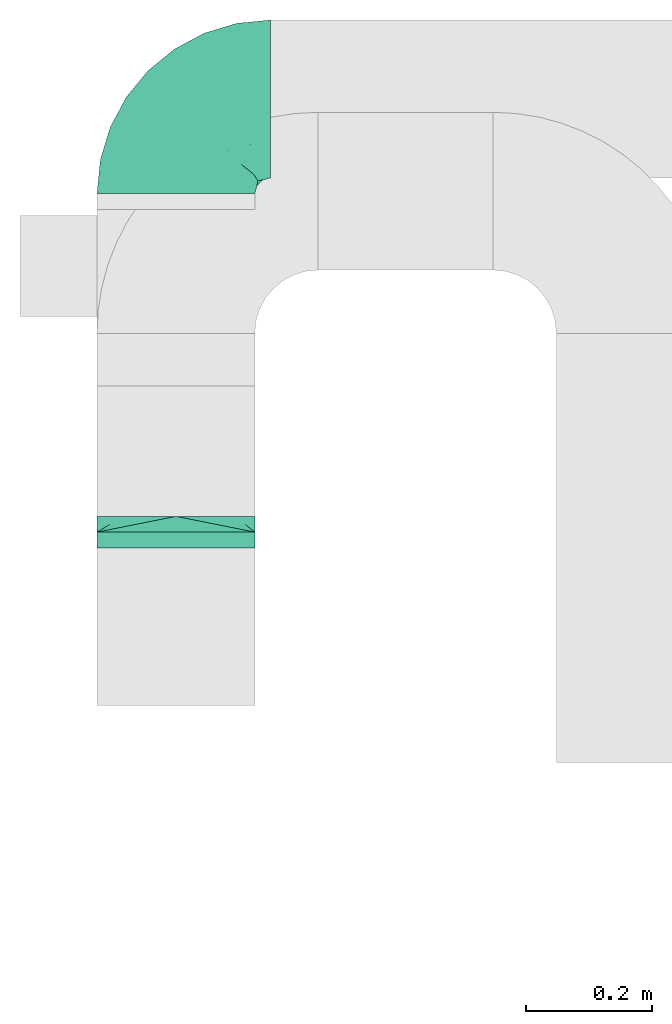
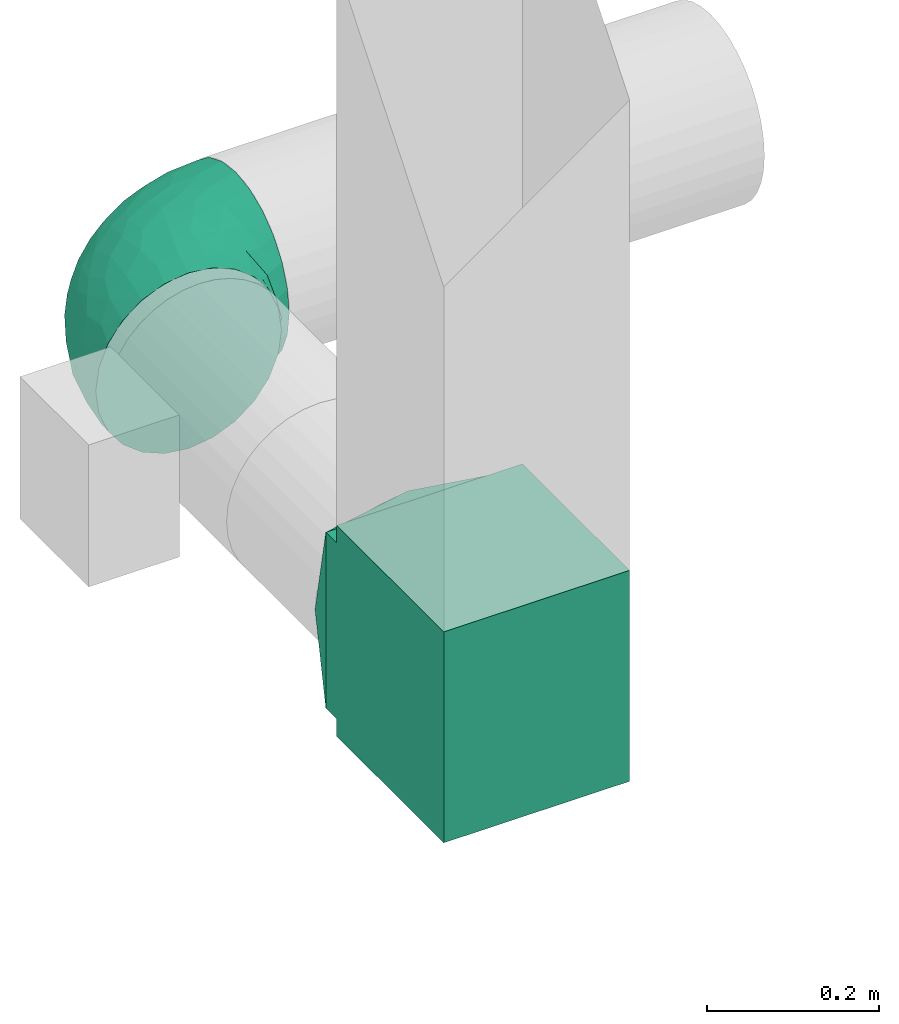
# One storey, part 3 of 5: 3 flow fittings.
"""IFC2X3 building model written with IfcOpenShell, lengths in millimetres."""

from ifc_helpers import new_model, entity, si_unit, converted_unit, derived_unit, direction, frame, origin, place, context, subcontext, project, spatial, polyline, outline, extrude, faceted_brep, source, transform, mapped, material, type_object, type_shapes, element, save


model = new_model("IFC2X3")

# Units and contexts
model_context = context("Model", 3, precision=0.01, world=origin(), true_north=direction((6.12303176911189e-17, 1.0)))
body_context = subcontext(model_context, "Body", "Model", "MODEL_VIEW")
ifc_project = project(units=[si_unit("LENGTHUNIT", "METRE", prefix="MILLI"), si_unit("AREAUNIT", "SQUARE_METRE"), si_unit("VOLUMEUNIT", "CUBIC_METRE"), converted_unit("PLANEANGLEUNIT", "DEGREE", entity("IfcRatioMeasure", 0.0174532925199433), si_unit("PLANEANGLEUNIT", "RADIAN"), dimensions=[0, 0, 0, 0, 0, 0, 0]), si_unit("MASSUNIT", "GRAM", prefix="KILO"), derived_unit("MASSDENSITYUNIT", [(si_unit("MASSUNIT", "GRAM", prefix="KILO"), 1), (si_unit("LENGTHUNIT", "METRE"), -3)]), si_unit("TIMEUNIT", "SECOND"), si_unit("FREQUENCYUNIT", "HERTZ"), si_unit("THERMODYNAMICTEMPERATUREUNIT", "DEGREE_CELSIUS"), derived_unit("THERMALTRANSMITTANCEUNIT", [(si_unit("MASSUNIT", "GRAM", prefix="KILO"), 1), (si_unit("THERMODYNAMICTEMPERATUREUNIT", "KELVIN"), -1), (si_unit("TIMEUNIT", "SECOND"), -3)]), derived_unit("VOLUMETRICFLOWRATEUNIT", [(si_unit("LENGTHUNIT", "METRE"), 3), (si_unit("TIMEUNIT", "SECOND"), -1)]), si_unit("ELECTRICCURRENTUNIT", "AMPERE"), si_unit("ELECTRICVOLTAGEUNIT", "VOLT"), si_unit("POWERUNIT", "WATT"), si_unit("FORCEUNIT", "NEWTON", prefix="KILO"), si_unit("ILLUMINANCEUNIT", "LUX"), si_unit("LUMINOUSFLUXUNIT", "LUMEN"), si_unit("LUMINOUSINTENSITYUNIT", "CANDELA"), derived_unit("USERDEFINED", [(si_unit("MASSUNIT", "GRAM", prefix="KILO"), -1), (si_unit("LENGTHUNIT", "METRE"), -2), (si_unit("TIMEUNIT", "SECOND"), 3), (si_unit("LUMINOUSFLUXUNIT", "LUMEN"), 1)]), derived_unit("LINEARVELOCITYUNIT", [(si_unit("LENGTHUNIT", "METRE"), 1), (si_unit("TIMEUNIT", "SECOND"), -1)]), si_unit("PRESSUREUNIT", "PASCAL"), derived_unit("USERDEFINED", [(si_unit("LENGTHUNIT", "METRE"), -2), (si_unit("MASSUNIT", "GRAM", prefix="KILO"), 1), (si_unit("TIMEUNIT", "SECOND"), -2)])], contexts=[model_context])

# Site, building, storey
site_placement = place(None, origin())
site = spatial("IfcSite", under=ifc_project, at=site_placement, CompositionType="ELEMENT")
building_placement = place(site_placement, origin())
building = spatial("IfcBuilding", under=site, at=building_placement, CompositionType="ELEMENT")
storey_placement = place(building_placement, frame((0.0, 0.0, 4000.0)))
storey = spatial("IfcBuildingStorey", under=building, at=storey_placement, Name="01 Level", CompositionType="ELEMENT", Elevation=4000.0)

# Flow fittings
duct_fitting_type_1 = type_object("IfcDuctFittingType", Name="Air_Elbow short_Circ", PredefinedType="NOTDEFINED")
shared_shape_1 = source(origin(), body_context, "Body", "Brep", [
    faceted_brep([(-150.0, -32.3523806378152, -120.740728286134), (-150.0, -62.5000000000001, -108.253175473055), (-150.0, -88.3883476483185, -88.3883476483184), (-150.0, -108.253175473055, -62.4999999999999), (-150.0, -120.740728286134, -32.3523806378151), (-150.0, -125.0, 0.0), (-150.0, -120.740728286133, 32.3523806378158), (-150.0, -108.253175473054, 62.5000000000006), (-150.0, -88.3883476483179, 88.3883476483189), (-150.0, -62.4999999999994, 108.253175473055), (-150.0, -47.426190318907, 114.496951879594), (-150.0, -32.3523806378145, 120.740728286134), (-150.0, 0.0, 125.0), (-150.0, 32.3523806378156, 120.740728286133), (-150.0, 62.5000000000004, 108.253175473055), (-150.0, 88.3883476483188, 88.3883476483181), (-150.0, 108.253175473055, 62.4999999999996), (-150.0, 120.740728286134, 32.3523806378147), (-150.0, 123.435651932551, 11.8824032670586), (-150.0, 125.0, 0.0), (-150.0, 123.435651957388, -11.8824030784058), (-150.0, 120.740728286133, -32.3523806378155), (-150.0, 108.253175473055, -62.5000000000003), (-150.0, 88.3883476483182, -88.3883476483186), (-150.0, 62.4999999999998, -108.253175473055), (-150.0, 32.3523806378149, -120.740728286134), (-150.0, 0.0, -125.0), (0.0, -150.0, -125.0), (32.3523806378157, -150.0, -120.740728286134), (62.5000000000006, -150.0, -108.253175473055), (88.3883476483191, -150.0, -88.3883476483186), (108.253175473056, -150.0, -62.5000000000003), (120.740728286134, -150.0, -32.3523806378155), (123.435651967915, -150.0, -11.882402998446), (125.0, -150.0, 0.0), (123.435651942407, -150.0, 11.8824031922038), (120.740728286134, -150.0, 32.3523806378147), (108.253175473056, -150.0, 62.4999999999996), (88.3883476483196, -150.0, 88.3883476483181), (62.5000000000013, -150.0, 108.253175473055), (32.3523806378164, -150.0, 120.740728286133), (0.0, -150.0, 125.0), (-32.3523806378137, -150.0, 120.740728286134), (-62.4999999999986, -150.0, 108.253175473055), (-88.3883476483171, -150.0, 88.3883476483189), (-108.253175473054, -150.0, 62.5000000000006), (-120.740728286133, -150.0, 32.3523806378158), (-125.0, -150.0, 0.0), (-120.740728286133, -150.0, -32.3523806378151), (-108.253175473054, -150.0, -62.4999999999999), (-88.3883476483177, -150.0, -88.3883476483184), (-62.4999999999993, -150.0, -108.253175473055), (-47.4261903189069, -150.0, -114.496951879594), (-32.3523806378144, -150.0, -120.740728286134), (61.5542541047513, 23.6180894533453, 0.0), (76.8166118284912, -4.34215934351885, 36.4784551593461), (78.654143383201, 2.78181408039032, 0.0), (-107.650286082481, 120.828917244489, 0.0), (-118.950410719399, 121.94188237809, 0.0), (-134.47520521655, 123.470941174946, 0.0), (-104.978291071801, 115.896211779269, 36.0762953828009), (-98.4001040789566, 53.9628430343128, 109.445004780609), (-72.3157335278814, 68.3433914970576, 94.5606631552989), (-104.893239881748, 80.8641300661028, 91.4382355521353), (-96.3501614455635, 119.715952110888, 0.0), (-9.85362544116063, -110.378344389653, 124.923923156167), (-42.4833938815038, -107.782088248638, 120.147094064889), (-86.153263795542, 100.695403874887, 61.7233478403087), (-65.0280946569744, 106.747383493999, 33.443557785531), (-74.6225764033372, 21.2831891292868, 119.356425571857), (-46.6576932994355, 45.2628664218306, 102.931281147801), (-72.3472176796021, -118.598046915095, 106.00707228478), (-30.181321363474, 90.8187429032163, 38.3247326160971), (-70.5561087725814, 111.891411775746, 0.0), (-122.641019976636, 101.950353756475, 70.1921456806148), (-116.029933078324, 22.4446697961388, 122.317161759311), (-3.87227453406602, 60.0293001979925, 66.4690229889152), (-6.5545406401204, 44.0646866272317, 85.350831949551), (31.0815829535711, 16.1832151821723, 80.3202993154639), (-124.863076426312, -35.02364091556, 120.752635411014), (-100.878102436648, -43.0002899009219, 120.764526140437), (-65.2460766604593, -23.6299006304857, 124.981338254694), (-108.839291442555, -9.81519021738238, 124.939227930759), (-40.0496486471489, -1.9751024241996, 120.175633139922), (-19.3649461243935, -39.6901954019144, 123.22697540265), (111.891411775747, -70.5561087725829, 0.0), (106.747383973922, -65.0280912143933, 33.4435522492635), (115.896212240375, -104.978289788922, 36.076293164084), (-128.779008055589, -97.2792215313154, 83.3343675755997), (-129.846276411156, -129.84627642804, 29.3795101662085), (-137.499999999999, -128.349364905389, 0.0), (-119.508978979081, -123.341462022577, 60.2918029167743), (-117.382833556128, -72.4228430829308, 106.251870907854), (-25.6262961621547, -80.1753214783878, 124.782747564482), (-131.548236956176, -110.790620858511, 65.1719471748524), (-35.2869113408269, 83.3156317546561, 59.3885364241187), (-8.79719392560859, 75.269004466267, 46.9066376982592), (80.8641305584726, -104.893240937849, 91.4382352904789), (53.9628368321699, -98.4001001508859, 109.445007566679), (22.4446672811422, -116.029929681511, 122.317162140699), (101.950355286479, -122.641017340516, 70.1921430199164), (-81.9960770469301, -82.9111806812523, 112.506499839482), (121.941882232658, -118.950409242795, 0.0), (54.4859475333804, -9.97269301512521, 77.8031341973232), (72.0838963385765, -41.0064832243528, 78.3617835611187), (71.251669566406, -11.4744102833441, 57.4040159418747), (5.67366256371018, 73.4168733312184, 25.8218410570659), (32.5558794954592, 52.5906940820025, 23.8275763366719), (23.6180894533467, 61.55425410475, 0.0), (-104.061743134415, -104.061741649423, 91.6204401768965), (100.695405783636, -86.1532561367086, 61.7233412541476), (85.8987630246562, -72.298942037013, 77.1305759551526), (21.2831826839793, -74.6225676704571, 119.356426312895), (45.2628557573736, -46.657677121917, 102.931282428265), (-128.349364905388, -137.5, 0.0), (-97.2792212827368, -128.779007172919, 83.3343682018964), (44.4543648263017, 44.4543648263003, 0.0), (-52.705139116163, -62.5335134626551, 123.521409265362), (-44.7620560995991, 104.066871440604, 0.0), (68.3433809087284, -72.3157185192085, 94.5606674302311), (16.162962522349, 57.6081885852494, 46.7813378836038), (39.0643086961098, 39.0643160658399, 42.9833221935425), (87.2978457655956, -45.1469719017519, 60.4141052051649), (-73.6770751262291, -45.4290804428845, 123.301126563982), (90.8187420929716, -30.1813146205812, 38.3247255432369), (104.066871440605, -44.7620560996006, 0.0), (91.3605074119029, -20.9901210096052, 0.0), (24.8419677176115, -18.7098050381526, 104.4628615233), (46.9444181295578, 18.5239913801244, 60.8208891980822), (-29.5778446799892, 20.3201363536925, 110.417514778129), (13.0080717069866, 10.2820614252128, 97.1887902869043), (-1.53394209146154, -80.1817000123714, 124.206375369784), (-65.4894356396677, 87.5368940232825, 72.0830916827234), (9.92439824324807, -37.6446897703782, 116.445568419899), (-3.04954297208558, -3.04952905280945, 110.823842282024), (2.7818140803917, 78.6541433831998, 0.0), (59.4075113977493, 18.3919768641063, 39.1397493302004), (-41.0065082221364, 72.0839038715865, 78.3617888442077), (-20.9901210096037, 91.3605074119017, 0.0), (119.715952110889, -96.3501614455651, 0.0), (-23.6299179988057, -65.2460778291534, -124.981338515222), (-62.5335140350356, -52.7051321522757, -123.521410009679), (-39.6901857853554, -19.3649451890522, -123.226974224734), (73.4168733742841, 5.67366166885961, -25.8218433127719), (52.5906917601974, 32.5558816629036, -23.8275777472421), (-110.378347073661, -9.85362190254904, -124.923923249535), (-35.0236472156293, -124.863059021426, -120.752634758897), (-107.782088925523, -42.4833910778036, -120.147094743061), (-65.0280943433708, 106.747382926782, -33.4435593699909), (-86.1532622275364, 100.695403598284, -61.7233476308542), (-104.978289397083, 115.896211531471, -36.0762952658108), (-129.846276430226, -129.846276387071, -29.3795102302433), (-110.790620399346, -131.548235360156, -65.1719489671012), (-128.779008894392, -97.2792211868359, -83.3343675827014), (-104.061744765902, -104.061740157582, -91.6204400852508), (-123.341462756194, -119.508979301124, -60.291801599493), (53.9628420250463, -98.4000971565888, -109.445004383699), (-82.9111719502085, -81.9960693312282, -112.50650546776), (-118.598049105409, -72.3472165670435, -106.007072416171), (-122.641019448242, 101.950353750649, -70.1921456050946), (-98.4001019855057, 53.9628440035923, -109.445003978822), (-104.893238223024, 80.8641303146933, -91.4382350282511), (80.8641292666627, -104.893234920637, -91.4382353967358), (-9.97270838371827, 54.485960500352, -77.8031316627462), (-41.0065049684125, 72.0839032542554, -78.3617877513776), (-11.4744255033641, 71.2516789045734, -57.4040162551542), (-4.34216444876671, 76.8166149897799, -36.4784554826068), (-80.1753222808587, -25.6262887954871, -124.782747920507), (-116.029931420384, 22.4446712385047, -122.317161393809), (45.2628607882706, -46.6576825738772, -102.931281121668), (68.3433887340013, -72.3157292909759, -94.5606641780198), (-9.8151830458522, -108.839262459516, -124.939228400111), (22.4446699556419, -116.029925989706, -122.317161437833), (-72.298953284581, 85.8987604849819, -77.1305835190378), (-97.2792209116865, -128.779005996318, -83.3343690779209), (-72.3157308447408, 68.3433918222031, -94.5606621128927), (-46.6576894105135, 45.2628676819038, -102.931279126956), (-72.422840670004, -117.382841409987, -106.251870399877), (21.2831853090833, -74.6225640045938, -119.356425105916), (101.950353353368, -122.641019823701, -70.1921462468134), (-43.0003002529277, -100.878091329174, -120.764524865091), (60.0292953493994, -3.87226817055985, -66.4690235395615), (44.0646797153192, -6.55452919959333, -85.3508306205825), (16.1832033989244, 31.0815970254922, -80.3202964529749), (100.695402688448, -86.1532621979624, -61.7233491707037), (106.747381524869, -65.0280939101863, -33.4435636729749), (115.896211010696, -104.978286786289, -36.0762955232767), (-1.97512261791953, -40.0496336831204, -120.175635225652), (75.2690016288807, -8.79719117487841, -46.9066400280846), (90.8187416032175, -30.181318578684, -38.3247323782698), (83.315631357607, -35.2869127496766, -59.388538235289), (39.0643108807276, 39.0643133486842, -42.9833232218422), (57.6081840561054, 16.162966744892, -46.7813401074288), (18.5239820708271, 46.9444270147629, -60.8208879439308), (-74.6225723501512, 21.2831916140966, -119.356424356291), (-45.1469861494655, 87.2978481709874, -60.4141116504016), (-45.4290965712264, -73.6770713110896, -123.301124768617), (-30.1813201883898, 90.818742779246, -38.3247313356157), (-18.7098212867178, 24.8419796072181, -104.462861687025), (20.3201251027192, -29.5778424846975, -110.417518980415), (10.2820459472016, 13.0080933749158, -97.1887865677227), (-80.1817048843535, -1.5339337664806, -124.206374751548), (87.5368918123803, -65.4894359750046, -72.0830947930252), (-37.6446965781717, 9.92440491577136, -116.445567816425), (-3.04953343548765, -3.04952712079592, -110.823838051094), (18.3919716152399, 59.4075155656008, -39.1397494553499), (72.083900742128, -41.0065066004899, -78.361791447751)], [[[0, 1, 2, 3, 4, 5, 6, 7, 8, 9, 10, 11, 12, 13, 14, 15, 16, 17, 18, 19, 20, 21, 22, 23, 24, 25, 26]], [[27, 28, 29, 30, 31, 32, 33, 34, 35, 36, 37, 38, 39, 40, 41, 42, 43, 44, 45, 46, 47, 48, 49, 50, 51, 52, 53]], [[54, 55, 56]], [[57, 58, 59, 19, 18, 17]], [[17, 16, 60]], [[61, 62, 63]], [[64, 57, 60]], [[65, 66, 42]], [[67, 68, 60]], [[63, 15, 14]], [[63, 14, 61]], [[69, 70, 61]], [[71, 44, 43]], [[68, 67, 72]], [[68, 73, 60]], [[74, 16, 15]], [[66, 71, 43]], [[12, 75, 13]], [[76, 77, 78]], [[79, 11, 10, 9]], [[80, 81, 82]], [[83, 81, 84]], [[85, 86, 87]], [[7, 88, 8]], [[6, 5, 89]], [[90, 89, 5]], [[46, 91, 89]], [[70, 62, 61]], [[8, 92, 9]], [[66, 65, 93]], [[94, 88, 7]], [[75, 69, 61]], [[72, 95, 96]], [[67, 60, 74]], [[38, 97, 39]], [[61, 14, 13]], [[98, 99, 40]], [[100, 38, 37]], [[101, 71, 66]], [[98, 40, 39]], [[36, 102, 87]], [[103, 104, 105]], [[97, 98, 39]], [[37, 36, 87]], [[106, 107, 108]], [[9, 92, 79]], [[35, 34, 102, 36]], [[101, 109, 71]], [[86, 110, 87]], [[110, 111, 97]], [[46, 89, 47]], [[112, 98, 113]], [[47, 89, 114]], [[7, 6, 94]], [[109, 91, 115]], [[108, 107, 116]], [[84, 81, 117]], [[46, 45, 91]], [[115, 45, 44]], [[68, 72, 118]], [[82, 12, 11]], [[119, 104, 113]], [[43, 42, 66]], [[42, 41, 65]], [[120, 121, 107]], [[110, 86, 122]], [[40, 99, 41]], [[12, 82, 75]], [[37, 87, 100]], [[117, 81, 123]], [[101, 123, 80]], [[109, 92, 88]], [[124, 125, 126]], [[113, 103, 127]], [[78, 128, 120]], [[129, 130, 77]], [[44, 71, 115]], [[101, 92, 109]], [[117, 66, 93]], [[99, 131, 65]], [[98, 97, 119]], [[110, 97, 100]], [[15, 63, 74]], [[95, 67, 132]], [[81, 69, 82]], [[69, 81, 83]], [[84, 133, 134]], [[65, 131, 93]], [[106, 108, 135]], [[96, 106, 72]], [[122, 111, 110]], [[54, 116, 136]], [[112, 113, 133]], [[127, 133, 113]], [[137, 70, 77]], [[134, 129, 83]], [[137, 76, 95]], [[127, 78, 130]], [[92, 101, 80]], [[117, 101, 66]], [[41, 99, 65]], [[112, 99, 98]], [[13, 75, 61]], [[69, 75, 82]], [[45, 115, 91]], [[109, 115, 71]], [[8, 88, 92]], [[91, 109, 94]], [[85, 125, 86]], [[138, 106, 135]], [[124, 86, 125]], [[87, 139, 85]], [[93, 84, 117]], [[131, 133, 84]], [[93, 131, 84]], [[112, 131, 99]], [[88, 94, 109]], [[89, 91, 94]], [[60, 57, 17]], [[139, 87, 102]], [[114, 89, 90]], [[94, 6, 89]], [[16, 74, 60]], [[67, 74, 63]], [[38, 100, 97]], [[110, 100, 87]], [[79, 92, 80]], [[79, 82, 11]], [[79, 80, 82]], [[107, 106, 120]], [[116, 107, 136]], [[98, 119, 113]], [[120, 106, 96]], [[138, 72, 106]], [[120, 96, 76]], [[95, 76, 96]], [[120, 76, 78]], [[77, 76, 137]], [[137, 95, 132]], [[95, 72, 67]], [[137, 132, 62]], [[132, 67, 63]], [[136, 121, 128]], [[128, 121, 120]], [[136, 128, 105]], [[103, 105, 128]], [[136, 105, 55]], [[124, 105, 122]], [[104, 103, 113]], [[78, 103, 128]], [[105, 124, 55]], [[107, 121, 136]], [[104, 119, 111]], [[97, 111, 119]], [[104, 111, 122]], [[104, 122, 105]], [[86, 124, 122]], [[63, 62, 132]], [[137, 62, 70]], [[117, 123, 101]], [[123, 81, 80]], [[70, 69, 129]], [[134, 83, 84]], [[83, 129, 69]], [[70, 129, 77]], [[127, 134, 133]], [[112, 133, 131]], [[134, 127, 130]], [[78, 127, 103]], [[134, 130, 129]], [[130, 78, 77]], [[138, 118, 72]], [[124, 126, 55]], [[64, 60, 73]], [[68, 118, 73]], [[136, 55, 54]], [[56, 55, 126]], [[140, 141, 142]], [[143, 144, 54]], [[0, 26, 145]], [[146, 53, 52, 51]], [[0, 147, 1]], [[148, 149, 150]], [[5, 151, 90]], [[49, 48, 152]], [[153, 154, 155]], [[144, 116, 54]], [[3, 2, 153]], [[156, 29, 28]], [[157, 158, 147]], [[3, 155, 4]], [[21, 150, 22]], [[158, 2, 1]], [[20, 19, 59, 58, 21]], [[22, 150, 159]], [[160, 24, 161]], [[162, 30, 29]], [[24, 23, 161]], [[163, 164, 165]], [[159, 23, 22]], [[108, 166, 135]], [[147, 145, 167]], [[160, 25, 24]], [[25, 160, 168]], [[157, 154, 158]], [[169, 170, 156]], [[114, 90, 151]], [[27, 171, 172]], [[151, 48, 47]], [[149, 173, 161]], [[152, 174, 49]], [[175, 164, 176]], [[51, 177, 146]], [[49, 174, 50]], [[1, 147, 158]], [[27, 172, 28]], [[172, 178, 156]], [[179, 31, 30]], [[180, 140, 171]], [[181, 182, 183]], [[51, 50, 177]], [[171, 27, 53]], [[25, 168, 26]], [[156, 178, 169]], [[184, 185, 186]], [[187, 140, 142]], [[188, 189, 190]], [[145, 147, 0]], [[156, 162, 29]], [[189, 185, 184]], [[191, 192, 193]], [[186, 139, 102]], [[186, 102, 32]], [[4, 155, 151]], [[32, 31, 186]], [[194, 160, 176]], [[162, 156, 170]], [[126, 189, 143]], [[73, 148, 150]], [[185, 85, 186]], [[151, 47, 114]], [[184, 186, 179]], [[149, 148, 195]], [[196, 140, 180]], [[157, 196, 180]], [[154, 177, 174]], [[197, 148, 118]], [[176, 163, 198]], [[193, 163, 165]], [[199, 200, 182]], [[2, 158, 153]], [[157, 177, 154]], [[141, 147, 167]], [[168, 201, 145]], [[160, 161, 175]], [[149, 161, 159]], [[30, 162, 179]], [[190, 184, 202]], [[140, 178, 171]], [[178, 140, 187]], [[142, 203, 204]], [[145, 201, 167]], [[143, 54, 56]], [[188, 143, 189]], [[195, 173, 149]], [[108, 116, 205]], [[194, 176, 203]], [[198, 203, 176]], [[206, 169, 182]], [[204, 199, 187]], [[206, 181, 190]], [[198, 183, 200]], [[177, 157, 180]], [[141, 157, 147]], [[26, 168, 145]], [[194, 168, 160]], [[28, 172, 156]], [[178, 172, 171]], [[3, 153, 155]], [[154, 153, 158]], [[50, 174, 177]], [[155, 154, 152]], [[73, 118, 148]], [[139, 186, 85]], [[197, 138, 166]], [[150, 64, 73]], [[167, 142, 141]], [[201, 203, 142]], [[167, 201, 142]], [[194, 201, 168]], [[174, 152, 154]], [[151, 155, 152]], [[150, 58, 57, 64]], [[58, 150, 21]], [[102, 34, 33, 32]], [[152, 48, 151]], [[5, 4, 151]], [[31, 179, 186]], [[184, 179, 162]], [[23, 159, 161]], [[149, 159, 150]], [[146, 177, 180]], [[146, 171, 53]], [[146, 180, 171]], [[192, 191, 144]], [[205, 116, 144]], [[143, 192, 144]], [[192, 143, 188]], [[126, 125, 189]], [[192, 188, 181]], [[190, 181, 188]], [[192, 181, 183]], [[182, 181, 206]], [[206, 190, 202]], [[190, 189, 184]], [[206, 202, 170]], [[202, 184, 162]], [[160, 175, 176]], [[205, 191, 193]], [[165, 205, 193]], [[183, 193, 192]], [[205, 165, 166]], [[197, 165, 195]], [[164, 163, 176]], [[183, 163, 193]], [[165, 197, 166]], [[144, 191, 205]], [[164, 175, 173]], [[161, 173, 175]], [[164, 173, 195]], [[164, 195, 165]], [[148, 197, 195]], [[162, 170, 202]], [[206, 170, 169]], [[196, 141, 140]], [[141, 196, 157]], [[169, 178, 199]], [[204, 187, 142]], [[187, 199, 178]], [[169, 199, 182]], [[198, 204, 203]], [[194, 203, 201]], [[204, 198, 200]], [[183, 198, 163]], [[204, 200, 199]], [[200, 183, 182]], [[185, 189, 125]], [[126, 143, 56]], [[197, 118, 138]], [[185, 125, 85]], [[205, 166, 108]], [[135, 166, 138]]]),
])
type_shapes(duct_fitting_type_1, [shared_shape_1])
flow_fitting_1_placement = place(storey_placement, frame((25195.9632723171, -67405.0175280858, 3510.0), z_axis=(0.0, 0.0, 1.0), x_axis=(0.0, 1.0, 0.0)))
element("IfcFlowFitting", 1, at=flow_fitting_1_placement, inside=storey, type_object=duct_fitting_type_1, Name="elbow_short_001:Air_Elbow short_Circ", ObjectType="elbow_short_001:Air_Elbow short_Circ", context=body_context, shape_type="MappedRepresentation", body=[
    mapped(shared_shape_1, transform((0.0, 0.0, 0.0), scale=1.0)),
])
duct_fitting_type_2 = type_object("IfcDuctFittingType", Name="Air_Rect", PredefinedType="NOTDEFINED")
shared_shape_2 = source(origin(), body_context, "Body", "SweptSolid", [
    extrude(outline(polyline([(-56.2499999999996, -150.0), (193.75, -150.0), (193.75, 150.0), (-56.2500000000005, 150.0), (-56.2500000000004, 125.0), (-81.2499999999999, 125.0), (-81.2499999999999, -125.0), (-56.2499999999996, -125.0), (-56.2499999999996, -150.0)])), frame((0.0, 68.75, -125.0), z_axis=(0.0, 0.0, 1.0), x_axis=(0.0, -1.0, 0.0)), (0.0, 0.0, 1.0), 250.0),
])
type_shapes(duct_fitting_type_2, [shared_shape_2])
flow_fitting_2_placement = place(storey_placement, frame((25195.9632723171, -68241.2395851399, 3510.0), z_axis=(1.0, 0.0, 0.0), x_axis=(0.0, 0.0, -1.0)))
element("IfcFlowFitting", 2, at=flow_fitting_2_placement, inside=storey, type_object=duct_fitting_type_2, Name="1_001:Air_Rect", ObjectType="1_001:Air_Rect", context=body_context, shape_type="MappedRepresentation", body=[
    mapped(shared_shape_2, transform((0.0, 0.0, 0.0), scale=1.0)),
])
ifc_material = material(Name="Material_Duct")
duct_fitting_type_3 = type_object("IfcDuctFittingType", Name="Air_Multi shape transition_Circ", PredefinedType="NOTDEFINED", material=ifc_material)
shared_shape_3 = source(origin(), body_context, "Body", "Brep", [
    faceted_brep([(25.0, 38.627124296869, -118.882064536893), (25.0, 56.0501404167142, -110.00459441688), (25.0, 73.4731565365595, -101.127124296867), (25.0, 87.3001404167141, -87.3001404167125), (25.0, 101.127124296869, -73.4731565365578), (25.0, 110.004594416882, -56.0501404167124), (25.0, 118.882064536894, -38.6271242968671), (25.0, 121.223496625785, -23.8439038991246), (25.0, 123.111748312892, -11.9219519495616), (25.0, 124.055874156446, -5.96097597478013), (25.0, 125.0, 0.0), (25.0, 124.055874155635, 5.96097597990369), (25.0, 123.11174831127, 11.9219519598073), (25.0, 121.22349662254, 23.8439039196147), (25.0, 118.882064536894, 38.6271242968685), (25.0, 110.004594416881, 56.0501404167139), (25.0, 101.127124296868, 73.4731565365593), (25.0, 87.3001404167137, 87.3001404167139), (25.0, 73.473156536559, 101.127124296869), (25.0, 56.0501404167136, 110.004594416881), (25.0, 38.6271242968682, 118.882064536894), (25.0, 23.8439038991258, 121.223496625785), (25.0, 11.9219519495628, 123.111748312892), (25.0, 5.96097597478125, 124.055874156446), (25.0, 0.0, 125.0), (25.0, -5.96097597990388, 124.055874155635), (25.0, -11.9219519598075, 123.11174831127), (25.0, -23.8439039196148, 121.22349662254), (25.0, -38.6271242968687, 118.882064536894), (25.0, -56.050140416714, 110.004594416881), (25.0, -73.4731565365594, 101.127124296868), (25.0, -87.300140416714, 87.3001404167136), (25.0, -101.127124296869, 73.4731565365589), (25.0, -110.004594416881, 56.0501404167135), (25.0, -118.882064536894, 38.6271242968681), (25.0, -121.223496625785, 23.8439038991257), (25.0, -123.111748312893, 11.9219519495627), (25.0, -124.055874156446, 5.96097597478117), (25.0, -125.0, 0.0), (25.0, -124.055874155635, -5.96097597990274), (25.0, -123.11174831127, -11.9219519598064), (25.0, -121.22349662254, -23.8439039196137), (25.0, -118.882064536894, -38.6271242968675), (25.0, -110.004594416881, -56.0501404167129), (25.0, -101.127124296868, -73.4731565365583), (25.0, -87.3001404167137, -87.3001404167129), (25.0, -73.4731565365591, -101.127124296868), (25.0, -56.0501404167137, -110.00459441688), (25.0, -38.6271242968683, -118.882064536893), (25.0, -23.8439038991258, -121.223496625784), (25.0, -11.9219519495628, -123.111748312892), (25.0, -5.9609759747813, -124.055874156445), (25.0, 0.0, -125.0), (25.0, 5.96097597990422, -124.055874155634), (25.0, 11.9219519598079, -123.111748311269), (25.0, 23.8439039196152, -121.223496622539), (0.0, -125.0, -125.0), (0.0, -125.0, 125.0), (0.0, 125.0, 125.0), (0.0, 125.0, -125.0), (13.0142783389037, 59.9286083054818, 125.0), (3.25356958472593, 108.732152076371, 125.0), (12.4999999334883, 103.93826768006, 109.288032538106), (16.0107087541778, 44.9464562291113, 125.0), (19.0071391694519, 29.9643041527408, 125.0), (22.0035695847259, 14.9821520763703, 125.0), (23.501784792363, 7.49107603818503, 125.0), (6.50713897169544, 125.0, 92.464305141524), (3.25356948584772, 125.0, 108.732152570763), (9.76070845754316, 125.0, 76.1964577122852), (13.0142779433909, 125.0, 59.9286102830464), (23.5017847429239, 125.0, 7.49107628538083), (22.0035694858477, 125.0, 14.9821525707616), (19.0071389716954, 125.0, 29.9643051415232), (16.0107084575432, 125.0, 44.9464577122848), (6.50713916945185, 92.4643041527413, 125.0), (9.76070875417778, 76.1964562291116, 125.0), (23.501784792363, 125.0, -7.49107603818391), (22.0035695847259, 125.0, -14.9821520763692), (19.0071391694518, 125.0, -29.9643041527398), (16.0107087541778, 125.0, -44.9464562291103), (13.0142783389037, 125.0, -59.9286083054808), (9.76070875417777, 125.0, -76.1964562291106), (6.50713916945185, 125.0, -92.4643041527404), (3.25356958472592, 125.0, -108.73215207637), (12.4999999334883, 109.288032538106, -103.938267680059), (6.50713897169543, 92.4643051415237, -125.0), (3.25356948584772, 108.732152570762, -125.0), (9.76070845754315, 76.196457712285, -125.0), (13.0142779433909, 59.9286102830464, -125.0), (23.5017847429239, 7.49107628538129, -125.0), (22.0035694858477, 14.982152570762, -125.0), (19.0071389716954, 29.9643051415235, -125.0), (16.0107084575431, 44.9464577122849, -125.0), (23.501784792363, -7.49107603818498, -125.0), (22.0035695847259, -14.9821520763701, -125.0), (19.0071391694519, -29.9643041527404, -125.0), (16.0107087541778, -44.9464562291108, -125.0), (13.0142783389037, -59.9286083054811, -125.0), (9.76070875417778, -76.1964562291107, -125.0), (6.50713916945185, -92.4643041527402, -125.0), (3.25356958472593, -108.73215207637, -125.0), (12.4999999334883, -103.938267680059, -109.288032538105), (6.50713897169544, -125.0, -92.4643051415225), (3.25356948584772, -125.0, -108.732152570761), (9.76070845754316, -125.0, -76.1964577122838), (13.0142779433909, -125.0, -59.9286102830451), (23.5017847429239, -125.0, -7.49107628537984), (22.0035694858477, -125.0, -14.9821525707606), (19.0071389716954, -125.0, -29.9643051415221), (16.0107084575432, -125.0, -44.9464577122836), (23.501784792363, -125.0, 7.49107603818499), (22.0035695847259, -125.0, 14.9821520763703), (19.0071391694519, -125.0, 29.9643041527409), (16.0107087541778, -125.0, 44.9464562291115), (13.0142783389037, -125.0, 59.9286083054821), (9.76070875417777, -125.0, 76.196456229112), (6.50713916945185, -125.0, 92.4643041527418), (3.25356958472593, -125.0, 108.732152076372), (12.4999999334883, -109.288032538105, 103.93826768006), (6.50713897169544, -92.4643051415224, 125.0), (3.25356948584772, -108.732152570761, 125.0), (9.76070845754316, -76.1964577122839, 125.0), (13.0142779433909, -59.9286102830454, 125.0), (23.5017847429239, -7.49107628538088, 125.0), (22.0035694858477, -14.9821525707615, 125.0), (19.0071389716954, -29.9643051415228, 125.0), (16.0107084575432, -44.9464577122841, 125.0)], [[[0, 1, 2, 3, 4, 5, 6, 7, 8, 9, 10, 11, 12, 13, 14, 15, 16, 17, 18, 19, 20, 21, 22, 23, 24, 25, 26, 27, 28, 29, 30, 31, 32, 33, 34, 35, 36, 37, 38, 39, 40, 41, 42, 43, 44, 45, 46, 47, 48, 49, 50, 51, 52, 53, 54, 55]], [[56, 57, 58, 59]], [[20, 19, 60]], [[61, 62, 58]], [[60, 63, 64, 65, 66, 24, 23, 22, 21, 20]], [[67, 68, 16]], [[18, 62, 61]], [[69, 67, 15, 70]], [[13, 12, 11, 10, 71, 72, 73, 74, 70, 14]], [[19, 18, 75]], [[76, 60, 19, 75]], [[15, 14, 70]], [[17, 68, 62]], [[61, 75, 18]], [[17, 16, 68]], [[17, 62, 18]], [[68, 58, 62]], [[16, 15, 67]], [[77, 78, 79, 80, 81, 82, 83, 84, 59, 58, 68, 67, 69, 70, 74, 73, 72, 71, 10]], [[6, 5, 81]], [[84, 85, 59]], [[81, 80, 79, 78, 77, 10, 9, 8, 7, 6]], [[86, 87, 2]], [[4, 85, 84]], [[88, 86, 1, 89]], [[55, 54, 53, 52, 90, 91, 92, 93, 89, 0]], [[5, 4, 83]], [[82, 81, 5, 83]], [[1, 0, 89]], [[3, 87, 85]], [[84, 83, 4]], [[3, 2, 87]], [[3, 85, 4]], [[87, 59, 85]], [[2, 1, 86]], [[56, 59, 87, 86, 88, 89, 93, 92, 91, 90, 52, 94, 95, 96, 97, 98, 99, 100, 101]], [[48, 47, 98]], [[101, 102, 56]], [[98, 97, 96, 95, 94, 52, 51, 50, 49, 48]], [[103, 104, 44]], [[46, 102, 101]], [[105, 103, 43, 106]], [[41, 40, 39, 38, 107, 108, 109, 110, 106, 42]], [[47, 46, 100]], [[99, 98, 47, 100]], [[43, 42, 106]], [[45, 104, 102]], [[101, 100, 46]], [[45, 44, 104]], [[45, 102, 46]], [[104, 56, 102]], [[44, 43, 103]], [[111, 112, 113, 114, 115, 116, 117, 118, 57, 56, 104, 103, 105, 106, 110, 109, 108, 107, 38]], [[34, 33, 115]], [[118, 119, 57]], [[115, 114, 113, 112, 111, 38, 37, 36, 35, 34]], [[120, 121, 30]], [[32, 119, 118]], [[122, 120, 29, 123]], [[27, 26, 25, 24, 124, 125, 126, 127, 123, 28]], [[33, 32, 117]], [[116, 115, 33, 117]], [[29, 28, 123]], [[31, 121, 119]], [[118, 117, 32]], [[31, 30, 121]], [[31, 119, 32]], [[121, 57, 119]], [[30, 29, 120]], [[66, 65, 64, 63, 60, 76, 75, 61, 58, 57, 121, 120, 122, 123, 127, 126, 125, 124, 24]]]),
])
type_shapes(duct_fitting_type_3, [shared_shape_3])
flow_fitting_3_placement = place(storey_placement, frame((25195.9632723171, -68091.2395851399, 3510.0), z_axis=(0.0, 0.0, 1.0), x_axis=(0.0, 1.0, 0.0)))
element("IfcFlowFitting", 3, at=flow_fitting_3_placement, inside=storey, type_object=duct_fitting_type_3, material=ifc_material, Name="multi_shape_trans_001:Air_Multi shape transition_Circ", ObjectType="multi_shape_trans_001:Air_Multi shape transition_Circ", context=body_context, shape_type="MappedRepresentation", body=[
    mapped(shared_shape_3, transform((0.0, 0.0, 0.0), scale=1.0)),
])

save(model, "model.ifc")
